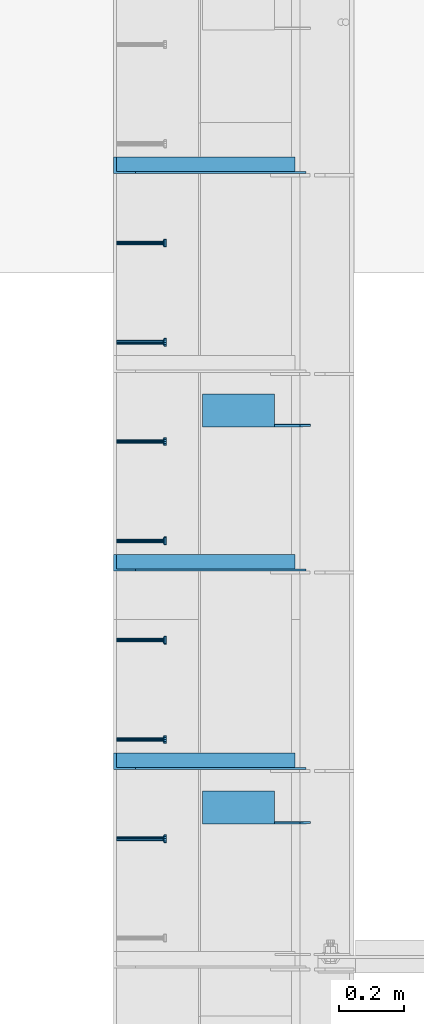
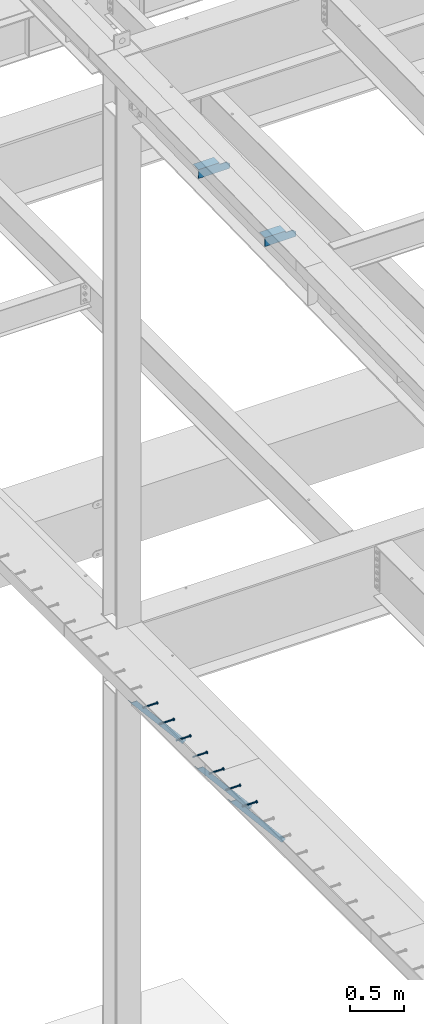
# One storey, part 1279 of 1763: 9 beams, 3 members, 9 elements without a shape of their own.
"""IFC2X3 building model written with IfcOpenShell, lengths in millimetres."""

from ifc_helpers import new_model, si_unit, frame, origin_with_axes, place, context, subcontext, project, spatial, faceted_brep, material, type_object, element, aggregate, save


model = new_model("IFC2X3")

# Units and contexts
model_context = context("Model", 3, precision=1e-05, world=origin_with_axes())
body_context = subcontext(model_context, "Body", "Model", "MODEL_VIEW")
ifc_project = project(units=[si_unit("LENGTHUNIT", "METRE", prefix="MILLI"), si_unit("AREAUNIT", "SQUARE_METRE"), si_unit("VOLUMEUNIT", "CUBIC_METRE"), si_unit("MASSUNIT", "GRAM", prefix="KILO"), si_unit("TIMEUNIT", "SECOND"), si_unit("PLANEANGLEUNIT", "RADIAN"), si_unit("SOLIDANGLEUNIT", "STERADIAN"), si_unit("THERMODYNAMICTEMPERATUREUNIT", "DEGREE_CELSIUS"), si_unit("LUMINOUSINTENSITYUNIT", "LUMEN")], contexts=[model_context])

# Site, building, storey
site_placement = place(None, origin_with_axes())
site = spatial("IfcSite", under=ifc_project, at=site_placement, CompositionType="ELEMENT")
building_placement = place(site_placement, origin_with_axes())
building = spatial("IfcBuilding", under=site, at=building_placement, Name="Undefined", CompositionType="ELEMENT")
storey_placement = place(building_placement, origin_with_axes())
storey = spatial("IfcBuildingStorey", under=building, at=storey_placement, Name="Undefined", CompositionType="ELEMENT", Elevation=0.0)

# Assembly, beam
assembly_1_placement = place(storey_placement, origin_with_axes())
assembly_1 = element("IfcElementAssembly", 1, at=assembly_1_placement, inside=storey, Name="HEADED STUD ANCHOR", AssemblyPlace="NOTDEFINED", PredefinedType="RIGID_FRAME")
ifc_material_1 = material(Name="STEEL/A108")
beam_type_1 = type_object("IfcBeamType", PredefinedType="NOTDEFINED")
beam_1_placement = place(assembly_1_placement, frame((-87975.5122736983, 41544.8750061035, 5268.91250001202), z_axis=(0.0, 0.0, -1.0), x_axis=(1.0, 0.0, 0.0)))
beam_1 = element("IfcBeam", 2, at=beam_1_placement, type_object=beam_type_1, material=ifc_material_1, Name="HEADED STUD ANCHOR", context=body_context, shape_type="Brep", body=[
    faceted_brep([(0.0, -3.1800000667572, 5.5), (0.0, -5.5, 3.1800000667572), (141.732000000002, -5.5, 3.1800000667572), (141.732000000002, -3.1800000667572, 5.5), (0.0, -6.34999999999491, 1.45519152283669e-11), (141.732000000002, -6.34999990463257, 0.0), (0.0, -5.5, -3.1800000667572), (141.732000000002, -5.5, -3.1800000667572), (0.0, -3.1800000667572, -5.5), (141.732000000002, -3.1800000667572, -5.5), (0.0, 0.0, -6.34999990463257), (141.732000000002, 0.0, -6.34999990463257), (0.0, 3.1800000667572, -5.5), (141.732000000002, 3.1800000667572, -5.5), (0.0, 5.5, -3.1800000667572), (141.732000000002, 5.5, -3.1800000667572), (0.0, 6.34999999999491, -2.91038304567337e-11), (141.732000000002, 6.34999990463257, 0.0), (0.0, 5.5, 3.1800000667572), (141.732000000002, 5.5, 3.1800000667572), (0.0, 3.1800000667572, 5.5), (141.732000000002, 3.1800000667572, 5.5), (0.0, 0.0, 6.34999990463257), (141.732000000002, 0.0, 6.34999990463257), (144.780000000001, -10.9899997711182, 6.34999990463257), (144.780000000001, -6.34000015258789, 10.9899997711182), (144.780000000001, -12.6999998092651, 0.0), (144.780000000001, -10.9899997711182, -6.34999990463257), (144.780000000001, -6.34000015258789, -10.9899997711182), (144.780000000001, 0.0, -12.6899995803833), (144.780000000001, 6.34000015258789, -10.9899997711182), (144.780000000001, 10.9899997711182, -6.34999990463257), (144.780000000001, 12.6999998092651, 0.0), (144.780000000001, 10.9899997711182, 6.34999990463257), (144.780000000001, 6.34000015258789, 10.9899997711182), (144.780000000001, 0.0, 12.6899995803833), (152.400000000001, -10.9899997711182, 6.34999990463257), (152.400000000001, -6.34000015258789, 10.9899997711182), (152.400000000001, -12.6999998092651, 0.0), (152.400000000001, -10.9899997711182, -6.34999990463257), (152.400000000001, -6.34000015258789, -10.9899997711182), (152.400000000001, 0.0, -12.6899995803833), (152.400000000001, 6.34000015258789, -10.9899997711182), (152.400000000001, 10.9899997711182, -6.34999990463257), (152.400000000001, 12.6999998092651, 0.0), (152.400000000001, 10.9899997711182, 6.34999990463257), (152.400000000001, 6.34000015258789, 10.9899997711182), (152.400000000001, 0.0, 12.6899995803833)], [[[0, 1, 2, 3]], [[1, 4, 5, 2]], [[4, 6, 7, 5]], [[6, 8, 9, 7]], [[8, 10, 11, 9]], [[10, 12, 13, 11]], [[12, 14, 15, 13]], [[14, 16, 17, 15]], [[16, 18, 19, 17]], [[18, 20, 21, 19]], [[20, 22, 23, 21]], [[22, 0, 3, 23]], [[22, 20, 18, 16, 14, 12, 10, 8, 6, 4, 1, 0]], [[3, 2, 24, 25]], [[2, 5, 26, 24]], [[5, 7, 27, 26]], [[7, 9, 28, 27]], [[9, 11, 29, 28]], [[11, 13, 30, 29]], [[13, 15, 31, 30]], [[15, 17, 32, 31]], [[17, 19, 33, 32]], [[19, 21, 34, 33]], [[21, 23, 35, 34]], [[23, 3, 25, 35]], [[25, 24, 36, 37]], [[24, 26, 38, 36]], [[26, 27, 39, 38]], [[27, 28, 40, 39]], [[28, 29, 41, 40]], [[29, 30, 42, 41]], [[30, 31, 43, 42]], [[31, 32, 44, 43]], [[32, 33, 45, 44]], [[33, 34, 46, 45]], [[34, 35, 47, 46]], [[35, 25, 37, 47]], [[38, 39, 40, 41, 42, 43, 44, 45, 46, 47, 37, 36]]]),
])
aggregate(assembly_1, [beam_1])

assembly_2_placement = place(storey_placement, origin_with_axes())
assembly_2 = element("IfcElementAssembly", 3, at=assembly_2_placement, inside=storey, Name="HEADED STUD ANCHOR", AssemblyPlace="NOTDEFINED", PredefinedType="RIGID_FRAME")
beam_2_placement = place(assembly_2_placement, frame((-87975.5122736983, 41849.6750061035, 5268.91250001202), z_axis=(0.0, 0.0, -1.0), x_axis=(1.0, 0.0, 0.0)))
beam_2 = element("IfcBeam", 4, at=beam_2_placement, type_object=beam_type_1, material=ifc_material_1, Name="HEADED STUD ANCHOR", context=body_context, shape_type="Brep", body=[
    faceted_brep([(0.0, -3.1800000667572, 5.5), (0.0, -5.5, 3.1800000667572), (141.732000000002, -5.5, 3.1800000667572), (141.732000000002, -3.1800000667572, 5.5), (0.0, -6.34999999999491, 1.45519152283669e-11), (141.732000000002, -6.34999990463257, 0.0), (0.0, -5.5, -3.1800000667572), (141.732000000002, -5.5, -3.1800000667572), (0.0, -3.1800000667572, -5.5), (141.732000000002, -3.1800000667572, -5.5), (0.0, 0.0, -6.34999990463257), (141.732000000002, 0.0, -6.34999990463257), (0.0, 3.1800000667572, -5.5), (141.732000000002, 3.1800000667572, -5.5), (0.0, 5.5, -3.1800000667572), (141.732000000002, 5.5, -3.1800000667572), (0.0, 6.34999999999491, -2.91038304567337e-11), (141.732000000002, 6.34999990463257, 0.0), (0.0, 5.5, 3.1800000667572), (141.732000000002, 5.5, 3.1800000667572), (0.0, 3.1800000667572, 5.5), (141.732000000002, 3.1800000667572, 5.5), (0.0, 0.0, 6.34999990463257), (141.732000000002, 0.0, 6.34999990463257), (144.780000000001, -10.9899997711182, 6.34999990463257), (144.780000000001, -6.34000015258789, 10.9899997711182), (144.780000000001, -12.6999998092651, 0.0), (144.780000000001, -10.9899997711182, -6.34999990463257), (144.780000000001, -6.34000015258789, -10.9899997711182), (144.780000000001, 0.0, -12.6899995803833), (144.780000000001, 6.34000015258789, -10.9899997711182), (144.780000000001, 10.9899997711182, -6.34999990463257), (144.780000000001, 12.6999998092651, 0.0), (144.780000000001, 10.9899997711182, 6.34999990463257), (144.780000000001, 6.34000015258789, 10.9899997711182), (144.780000000001, 0.0, 12.6899995803833), (152.400000000001, -10.9899997711182, 6.34999990463257), (152.400000000001, -6.34000015258789, 10.9899997711182), (152.400000000001, -12.6999998092651, 0.0), (152.400000000001, -10.9899997711182, -6.34999990463257), (152.400000000001, -6.34000015258789, -10.9899997711182), (152.400000000001, 0.0, -12.6899995803833), (152.400000000001, 6.34000015258789, -10.9899997711182), (152.400000000001, 10.9899997711182, -6.34999990463257), (152.400000000001, 12.6999998092651, 0.0), (152.400000000001, 10.9899997711182, 6.34999990463257), (152.400000000001, 6.34000015258789, 10.9899997711182), (152.400000000001, 0.0, 12.6899995803833)], [[[0, 1, 2, 3]], [[1, 4, 5, 2]], [[4, 6, 7, 5]], [[6, 8, 9, 7]], [[8, 10, 11, 9]], [[10, 12, 13, 11]], [[12, 14, 15, 13]], [[14, 16, 17, 15]], [[16, 18, 19, 17]], [[18, 20, 21, 19]], [[20, 22, 23, 21]], [[22, 0, 3, 23]], [[22, 20, 18, 16, 14, 12, 10, 8, 6, 4, 1, 0]], [[3, 2, 24, 25]], [[2, 5, 26, 24]], [[5, 7, 27, 26]], [[7, 9, 28, 27]], [[9, 11, 29, 28]], [[11, 13, 30, 29]], [[13, 15, 31, 30]], [[15, 17, 32, 31]], [[17, 19, 33, 32]], [[19, 21, 34, 33]], [[21, 23, 35, 34]], [[23, 3, 25, 35]], [[25, 24, 36, 37]], [[24, 26, 38, 36]], [[26, 27, 39, 38]], [[27, 28, 40, 39]], [[28, 29, 41, 40]], [[29, 30, 42, 41]], [[30, 31, 43, 42]], [[31, 32, 44, 43]], [[32, 33, 45, 44]], [[33, 34, 46, 45]], [[34, 35, 47, 46]], [[35, 25, 37, 47]], [[38, 39, 40, 41, 42, 43, 44, 45, 46, 47, 37, 36]]]),
])
aggregate(assembly_2, [beam_2])

assembly_3_placement = place(storey_placement, origin_with_axes())
assembly_3 = element("IfcElementAssembly", 5, at=assembly_3_placement, inside=storey, Name="HEADED STUD ANCHOR", AssemblyPlace="NOTDEFINED", PredefinedType="RIGID_FRAME")
beam_3_placement = place(assembly_3_placement, frame((-87975.5122736983, 42154.4750061035, 5268.91250001202), z_axis=(0.0, 0.0, -1.0), x_axis=(1.0, 0.0, 0.0)))
beam_3 = element("IfcBeam", 6, at=beam_3_placement, type_object=beam_type_1, material=ifc_material_1, Name="HEADED STUD ANCHOR", context=body_context, shape_type="Brep", body=[
    faceted_brep([(0.0, -3.1800000667572, 5.5), (0.0, -5.5, 3.1800000667572), (141.732000000002, -5.5, 3.1800000667572), (141.732000000002, -3.1800000667572, 5.5), (0.0, -6.34999999999491, 1.45519152283669e-11), (141.732000000002, -6.34999990463257, 0.0), (0.0, -5.5, -3.1800000667572), (141.732000000002, -5.5, -3.1800000667572), (0.0, -3.1800000667572, -5.5), (141.732000000002, -3.1800000667572, -5.5), (0.0, 0.0, -6.34999990463257), (141.732000000002, 0.0, -6.34999990463257), (0.0, 3.1800000667572, -5.5), (141.732000000002, 3.1800000667572, -5.5), (0.0, 5.5, -3.1800000667572), (141.732000000002, 5.5, -3.1800000667572), (0.0, 6.34999999999491, -2.91038304567337e-11), (141.732000000002, 6.34999990463257, 0.0), (0.0, 5.5, 3.1800000667572), (141.732000000002, 5.5, 3.1800000667572), (0.0, 3.1800000667572, 5.5), (141.732000000002, 3.1800000667572, 5.5), (0.0, 0.0, 6.34999990463257), (141.732000000002, 0.0, 6.34999990463257), (144.780000000001, -10.9899997711182, 6.34999990463257), (144.780000000001, -6.34000015258789, 10.9899997711182), (144.780000000001, -12.6999998092651, 0.0), (144.780000000001, -10.9899997711182, -6.34999990463257), (144.780000000001, -6.34000015258789, -10.9899997711182), (144.780000000001, 0.0, -12.6899995803833), (144.780000000001, 6.34000015258789, -10.9899997711182), (144.780000000001, 10.9899997711182, -6.34999990463257), (144.780000000001, 12.6999998092651, 0.0), (144.780000000001, 10.9899997711182, 6.34999990463257), (144.780000000001, 6.34000015258789, 10.9899997711182), (144.780000000001, 0.0, 12.6899995803833), (152.400000000001, -10.9899997711182, 6.34999990463257), (152.400000000001, -6.34000015258789, 10.9899997711182), (152.400000000001, -12.6999998092651, 0.0), (152.400000000001, -10.9899997711182, -6.34999990463257), (152.400000000001, -6.34000015258789, -10.9899997711182), (152.400000000001, 0.0, -12.6899995803833), (152.400000000001, 6.34000015258789, -10.9899997711182), (152.400000000001, 10.9899997711182, -6.34999990463257), (152.400000000001, 12.6999998092651, 0.0), (152.400000000001, 10.9899997711182, 6.34999990463257), (152.400000000001, 6.34000015258789, 10.9899997711182), (152.400000000001, 0.0, 12.6899995803833)], [[[0, 1, 2, 3]], [[1, 4, 5, 2]], [[4, 6, 7, 5]], [[6, 8, 9, 7]], [[8, 10, 11, 9]], [[10, 12, 13, 11]], [[12, 14, 15, 13]], [[14, 16, 17, 15]], [[16, 18, 19, 17]], [[18, 20, 21, 19]], [[20, 22, 23, 21]], [[22, 0, 3, 23]], [[22, 20, 18, 16, 14, 12, 10, 8, 6, 4, 1, 0]], [[3, 2, 24, 25]], [[2, 5, 26, 24]], [[5, 7, 27, 26]], [[7, 9, 28, 27]], [[9, 11, 29, 28]], [[11, 13, 30, 29]], [[13, 15, 31, 30]], [[15, 17, 32, 31]], [[17, 19, 33, 32]], [[19, 21, 34, 33]], [[21, 23, 35, 34]], [[23, 3, 25, 35]], [[25, 24, 36, 37]], [[24, 26, 38, 36]], [[26, 27, 39, 38]], [[27, 28, 40, 39]], [[28, 29, 41, 40]], [[29, 30, 42, 41]], [[30, 31, 43, 42]], [[31, 32, 44, 43]], [[32, 33, 45, 44]], [[33, 34, 46, 45]], [[34, 35, 47, 46]], [[35, 25, 37, 47]], [[38, 39, 40, 41, 42, 43, 44, 45, 46, 47, 37, 36]]]),
])
aggregate(assembly_3, [beam_3])

assembly_4_placement = place(storey_placement, origin_with_axes())
assembly_4 = element("IfcElementAssembly", 7, at=assembly_4_placement, inside=storey, Name="HEADED STUD ANCHOR", AssemblyPlace="NOTDEFINED", PredefinedType="RIGID_FRAME")
beam_4_placement = place(assembly_4_placement, frame((-87975.5122736983, 42459.2750061035, 5268.91250001202), z_axis=(0.0, 0.0, -1.0), x_axis=(1.0, 0.0, 0.0)))
beam_4 = element("IfcBeam", 8, at=beam_4_placement, type_object=beam_type_1, material=ifc_material_1, Name="HEADED STUD ANCHOR", context=body_context, shape_type="Brep", body=[
    faceted_brep([(0.0, -3.1800000667572, 5.5), (0.0, -5.5, 3.1800000667572), (141.732000000002, -5.5, 3.1800000667572), (141.732000000002, -3.1800000667572, 5.5), (0.0, -6.34999999999491, 1.45519152283669e-11), (141.732000000002, -6.34999990463257, 0.0), (0.0, -5.5, -3.1800000667572), (141.732000000002, -5.5, -3.1800000667572), (0.0, -3.1800000667572, -5.5), (141.732000000002, -3.1800000667572, -5.5), (0.0, 0.0, -6.34999990463257), (141.732000000002, 0.0, -6.34999990463257), (0.0, 3.1800000667572, -5.5), (141.732000000002, 3.1800000667572, -5.5), (0.0, 5.5, -3.1800000667572), (141.732000000002, 5.5, -3.1800000667572), (0.0, 6.34999999999491, -2.91038304567337e-11), (141.732000000002, 6.34999990463257, 0.0), (0.0, 5.5, 3.1800000667572), (141.732000000002, 5.5, 3.1800000667572), (0.0, 3.1800000667572, 5.5), (141.732000000002, 3.1800000667572, 5.5), (0.0, 0.0, 6.34999990463257), (141.732000000002, 0.0, 6.34999990463257), (144.780000000001, -10.9899997711182, 6.34999990463257), (144.780000000001, -6.34000015258789, 10.9899997711182), (144.780000000001, -12.6999998092651, 0.0), (144.780000000001, -10.9899997711182, -6.34999990463257), (144.780000000001, -6.34000015258789, -10.9899997711182), (144.780000000001, 0.0, -12.6899995803833), (144.780000000001, 6.34000015258789, -10.9899997711182), (144.780000000001, 10.9899997711182, -6.34999990463257), (144.780000000001, 12.6999998092651, 0.0), (144.780000000001, 10.9899997711182, 6.34999990463257), (144.780000000001, 6.34000015258789, 10.9899997711182), (144.780000000001, 0.0, 12.6899995803833), (152.400000000001, -10.9899997711182, 6.34999990463257), (152.400000000001, -6.34000015258789, 10.9899997711182), (152.400000000001, -12.6999998092651, 0.0), (152.400000000001, -10.9899997711182, -6.34999990463257), (152.400000000001, -6.34000015258789, -10.9899997711182), (152.400000000001, 0.0, -12.6899995803833), (152.400000000001, 6.34000015258789, -10.9899997711182), (152.400000000001, 10.9899997711182, -6.34999990463257), (152.400000000001, 12.6999998092651, 0.0), (152.400000000001, 10.9899997711182, 6.34999990463257), (152.400000000001, 6.34000015258789, 10.9899997711182), (152.400000000001, 0.0, 12.6899995803833)], [[[0, 1, 2, 3]], [[1, 4, 5, 2]], [[4, 6, 7, 5]], [[6, 8, 9, 7]], [[8, 10, 11, 9]], [[10, 12, 13, 11]], [[12, 14, 15, 13]], [[14, 16, 17, 15]], [[16, 18, 19, 17]], [[18, 20, 21, 19]], [[20, 22, 23, 21]], [[22, 0, 3, 23]], [[22, 20, 18, 16, 14, 12, 10, 8, 6, 4, 1, 0]], [[3, 2, 24, 25]], [[2, 5, 26, 24]], [[5, 7, 27, 26]], [[7, 9, 28, 27]], [[9, 11, 29, 28]], [[11, 13, 30, 29]], [[13, 15, 31, 30]], [[15, 17, 32, 31]], [[17, 19, 33, 32]], [[19, 21, 34, 33]], [[21, 23, 35, 34]], [[23, 3, 25, 35]], [[25, 24, 36, 37]], [[24, 26, 38, 36]], [[26, 27, 39, 38]], [[27, 28, 40, 39]], [[28, 29, 41, 40]], [[29, 30, 42, 41]], [[30, 31, 43, 42]], [[31, 32, 44, 43]], [[32, 33, 45, 44]], [[33, 34, 46, 45]], [[34, 35, 47, 46]], [[35, 25, 37, 47]], [[38, 39, 40, 41, 42, 43, 44, 45, 46, 47, 37, 36]]]),
])
aggregate(assembly_4, [beam_4])

assembly_5_placement = place(storey_placement, origin_with_axes())
assembly_5 = element("IfcElementAssembly", 9, at=assembly_5_placement, inside=storey, Name="HEADED STUD ANCHOR", AssemblyPlace="NOTDEFINED", PredefinedType="RIGID_FRAME")
beam_5_placement = place(assembly_5_placement, frame((-87975.5122736983, 42764.0750061035, 5268.91250001202), z_axis=(0.0, 0.0, -1.0), x_axis=(1.0, 0.0, 0.0)))
beam_5 = element("IfcBeam", 10, at=beam_5_placement, type_object=beam_type_1, material=ifc_material_1, Name="HEADED STUD ANCHOR", context=body_context, shape_type="Brep", body=[
    faceted_brep([(0.0, -3.1800000667572, 5.5), (0.0, -5.5, 3.1800000667572), (141.732000000002, -5.5, 3.1800000667572), (141.732000000002, -3.1800000667572, 5.5), (0.0, -6.34999999999491, 1.45519152283669e-11), (141.732000000002, -6.34999990463257, 0.0), (0.0, -5.5, -3.1800000667572), (141.732000000002, -5.5, -3.1800000667572), (0.0, -3.1800000667572, -5.5), (141.732000000002, -3.1800000667572, -5.5), (0.0, 0.0, -6.34999990463257), (141.732000000002, 0.0, -6.34999990463257), (0.0, 3.1800000667572, -5.5), (141.732000000002, 3.1800000667572, -5.5), (0.0, 5.5, -3.1800000667572), (141.732000000002, 5.5, -3.1800000667572), (0.0, 6.34999999999491, -2.91038304567337e-11), (141.732000000002, 6.34999990463257, 0.0), (0.0, 5.5, 3.1800000667572), (141.732000000002, 5.5, 3.1800000667572), (0.0, 3.1800000667572, 5.5), (141.732000000002, 3.1800000667572, 5.5), (0.0, 0.0, 6.34999990463257), (141.732000000002, 0.0, 6.34999990463257), (144.780000000001, -10.9899997711182, 6.34999990463257), (144.780000000001, -6.34000015258789, 10.9899997711182), (144.780000000001, -12.6999998092651, 0.0), (144.780000000001, -10.9899997711182, -6.34999990463257), (144.780000000001, -6.34000015258789, -10.9899997711182), (144.780000000001, 0.0, -12.6899995803833), (144.780000000001, 6.34000015258789, -10.9899997711182), (144.780000000001, 10.9899997711182, -6.34999990463257), (144.780000000001, 12.6999998092651, 0.0), (144.780000000001, 10.9899997711182, 6.34999990463257), (144.780000000001, 6.34000015258789, 10.9899997711182), (144.780000000001, 0.0, 12.6899995803833), (152.400000000001, -10.9899997711182, 6.34999990463257), (152.400000000001, -6.34000015258789, 10.9899997711182), (152.400000000001, -12.6999998092651, 0.0), (152.400000000001, -10.9899997711182, -6.34999990463257), (152.400000000001, -6.34000015258789, -10.9899997711182), (152.400000000001, 0.0, -12.6899995803833), (152.400000000001, 6.34000015258789, -10.9899997711182), (152.400000000001, 10.9899997711182, -6.34999990463257), (152.400000000001, 12.6999998092651, 0.0), (152.400000000001, 10.9899997711182, 6.34999990463257), (152.400000000001, 6.34000015258789, 10.9899997711182), (152.400000000001, 0.0, 12.6899995803833)], [[[0, 1, 2, 3]], [[1, 4, 5, 2]], [[4, 6, 7, 5]], [[6, 8, 9, 7]], [[8, 10, 11, 9]], [[10, 12, 13, 11]], [[12, 14, 15, 13]], [[14, 16, 17, 15]], [[16, 18, 19, 17]], [[18, 20, 21, 19]], [[20, 22, 23, 21]], [[22, 0, 3, 23]], [[22, 20, 18, 16, 14, 12, 10, 8, 6, 4, 1, 0]], [[3, 2, 24, 25]], [[2, 5, 26, 24]], [[5, 7, 27, 26]], [[7, 9, 28, 27]], [[9, 11, 29, 28]], [[11, 13, 30, 29]], [[13, 15, 31, 30]], [[15, 17, 32, 31]], [[17, 19, 33, 32]], [[19, 21, 34, 33]], [[21, 23, 35, 34]], [[23, 3, 25, 35]], [[25, 24, 36, 37]], [[24, 26, 38, 36]], [[26, 27, 39, 38]], [[27, 28, 40, 39]], [[28, 29, 41, 40]], [[29, 30, 42, 41]], [[30, 31, 43, 42]], [[31, 32, 44, 43]], [[32, 33, 45, 44]], [[33, 34, 46, 45]], [[34, 35, 47, 46]], [[35, 25, 37, 47]], [[38, 39, 40, 41, 42, 43, 44, 45, 46, 47, 37, 36]]]),
])
aggregate(assembly_5, [beam_5])

assembly_6_placement = place(storey_placement, origin_with_axes())
assembly_6 = element("IfcElementAssembly", 11, at=assembly_6_placement, inside=storey, Name="HEADED STUD ANCHOR", AssemblyPlace="NOTDEFINED", PredefinedType="RIGID_FRAME")
beam_6_placement = place(assembly_6_placement, frame((-87975.5122736983, 43068.8750061035, 5268.91250001202), z_axis=(0.0, 0.0, -1.0), x_axis=(1.0, 0.0, 0.0)))
beam_6 = element("IfcBeam", 12, at=beam_6_placement, type_object=beam_type_1, material=ifc_material_1, Name="HEADED STUD ANCHOR", context=body_context, shape_type="Brep", body=[
    faceted_brep([(0.0, -3.1800000667572, 5.5), (0.0, -5.5, 3.1800000667572), (141.732000000002, -5.5, 3.1800000667572), (141.732000000002, -3.1800000667572, 5.5), (0.0, -6.34999999999491, 1.45519152283669e-11), (141.732000000002, -6.34999990463257, 0.0), (0.0, -5.5, -3.1800000667572), (141.732000000002, -5.5, -3.1800000667572), (0.0, -3.1800000667572, -5.5), (141.732000000002, -3.1800000667572, -5.5), (0.0, 0.0, -6.34999990463257), (141.732000000002, 0.0, -6.34999990463257), (0.0, 3.1800000667572, -5.5), (141.732000000002, 3.1800000667572, -5.5), (0.0, 5.5, -3.1800000667572), (141.732000000002, 5.5, -3.1800000667572), (0.0, 6.34999999999491, -2.91038304567337e-11), (141.732000000002, 6.34999990463257, 0.0), (0.0, 5.5, 3.1800000667572), (141.732000000002, 5.5, 3.1800000667572), (0.0, 3.1800000667572, 5.5), (141.732000000002, 3.1800000667572, 5.5), (0.0, 0.0, 6.34999990463257), (141.732000000002, 0.0, 6.34999990463257), (144.780000000001, -10.9899997711182, 6.34999990463257), (144.780000000001, -6.34000015258789, 10.9899997711182), (144.780000000001, -12.6999998092651, 0.0), (144.780000000001, -10.9899997711182, -6.34999990463257), (144.780000000001, -6.34000015258789, -10.9899997711182), (144.780000000001, 0.0, -12.6899995803833), (144.780000000001, 6.34000015258789, -10.9899997711182), (144.780000000001, 10.9899997711182, -6.34999990463257), (144.780000000001, 12.6999998092651, 0.0), (144.780000000001, 10.9899997711182, 6.34999990463257), (144.780000000001, 6.34000015258789, 10.9899997711182), (144.780000000001, 0.0, 12.6899995803833), (152.400000000001, -10.9899997711182, 6.34999990463257), (152.400000000001, -6.34000015258789, 10.9899997711182), (152.400000000001, -12.6999998092651, 0.0), (152.400000000001, -10.9899997711182, -6.34999990463257), (152.400000000001, -6.34000015258789, -10.9899997711182), (152.400000000001, 0.0, -12.6899995803833), (152.400000000001, 6.34000015258789, -10.9899997711182), (152.400000000001, 10.9899997711182, -6.34999990463257), (152.400000000001, 12.6999998092651, 0.0), (152.400000000001, 10.9899997711182, 6.34999990463257), (152.400000000001, 6.34000015258789, 10.9899997711182), (152.400000000001, 0.0, 12.6899995803833)], [[[0, 1, 2, 3]], [[1, 4, 5, 2]], [[4, 6, 7, 5]], [[6, 8, 9, 7]], [[8, 10, 11, 9]], [[10, 12, 13, 11]], [[12, 14, 15, 13]], [[14, 16, 17, 15]], [[16, 18, 19, 17]], [[18, 20, 21, 19]], [[20, 22, 23, 21]], [[22, 0, 3, 23]], [[22, 20, 18, 16, 14, 12, 10, 8, 6, 4, 1, 0]], [[3, 2, 24, 25]], [[2, 5, 26, 24]], [[5, 7, 27, 26]], [[7, 9, 28, 27]], [[9, 11, 29, 28]], [[11, 13, 30, 29]], [[13, 15, 31, 30]], [[15, 17, 32, 31]], [[17, 19, 33, 32]], [[19, 21, 34, 33]], [[21, 23, 35, 34]], [[23, 3, 25, 35]], [[25, 24, 36, 37]], [[24, 26, 38, 36]], [[26, 27, 39, 38]], [[27, 28, 40, 39]], [[28, 29, 41, 40]], [[29, 30, 42, 41]], [[30, 31, 43, 42]], [[31, 32, 44, 43]], [[32, 33, 45, 44]], [[33, 34, 46, 45]], [[34, 35, 47, 46]], [[35, 25, 37, 47]], [[38, 39, 40, 41, 42, 43, 44, 45, 46, 47, 37, 36]]]),
])
aggregate(assembly_6, [beam_6])

assembly_7_placement = place(storey_placement, origin_with_axes())
assembly_7 = element("IfcElementAssembly", 13, at=assembly_7_placement, inside=storey, Name="HEADED STUD ANCHOR", AssemblyPlace="NOTDEFINED", PredefinedType="RIGID_FRAME")
beam_7_placement = place(assembly_7_placement, frame((-87975.5122736983, 43373.6750061035, 5268.91250001202), z_axis=(0.0, 0.0, -1.0), x_axis=(1.0, 0.0, 0.0)))
beam_7 = element("IfcBeam", 14, at=beam_7_placement, type_object=beam_type_1, material=ifc_material_1, Name="HEADED STUD ANCHOR", context=body_context, shape_type="Brep", body=[
    faceted_brep([(0.0, -3.1800000667572, 5.5), (0.0, -5.5, 3.1800000667572), (141.732000000002, -5.5, 3.1800000667572), (141.732000000002, -3.1800000667572, 5.5), (0.0, -6.34999999999491, 1.45519152283669e-11), (141.732000000002, -6.34999990463257, 0.0), (0.0, -5.5, -3.1800000667572), (141.732000000002, -5.5, -3.1800000667572), (0.0, -3.1800000667572, -5.5), (141.732000000002, -3.1800000667572, -5.5), (0.0, 0.0, -6.34999990463257), (141.732000000002, 0.0, -6.34999990463257), (0.0, 3.1800000667572, -5.5), (141.732000000002, 3.1800000667572, -5.5), (0.0, 5.5, -3.1800000667572), (141.732000000002, 5.5, -3.1800000667572), (0.0, 6.34999999999491, -2.91038304567337e-11), (141.732000000002, 6.34999990463257, 0.0), (0.0, 5.5, 3.1800000667572), (141.732000000002, 5.5, 3.1800000667572), (0.0, 3.1800000667572, 5.5), (141.732000000002, 3.1800000667572, 5.5), (0.0, 0.0, 6.34999990463257), (141.732000000002, 0.0, 6.34999990463257), (144.780000000001, -10.9899997711182, 6.34999990463257), (144.780000000001, -6.34000015258789, 10.9899997711182), (144.780000000001, -12.6999998092651, 0.0), (144.780000000001, -10.9899997711182, -6.34999990463257), (144.780000000001, -6.34000015258789, -10.9899997711182), (144.780000000001, 0.0, -12.6899995803833), (144.780000000001, 6.34000015258789, -10.9899997711182), (144.780000000001, 10.9899997711182, -6.34999990463257), (144.780000000001, 12.6999998092651, 0.0), (144.780000000001, 10.9899997711182, 6.34999990463257), (144.780000000001, 6.34000015258789, 10.9899997711182), (144.780000000001, 0.0, 12.6899995803833), (152.400000000001, -10.9899997711182, 6.34999990463257), (152.400000000001, -6.34000015258789, 10.9899997711182), (152.400000000001, -12.6999998092651, 0.0), (152.400000000001, -10.9899997711182, -6.34999990463257), (152.400000000001, -6.34000015258789, -10.9899997711182), (152.400000000001, 0.0, -12.6899995803833), (152.400000000001, 6.34000015258789, -10.9899997711182), (152.400000000001, 10.9899997711182, -6.34999990463257), (152.400000000001, 12.6999998092651, 0.0), (152.400000000001, 10.9899997711182, 6.34999990463257), (152.400000000001, 6.34000015258789, 10.9899997711182), (152.400000000001, 0.0, 12.6899995803833)], [[[0, 1, 2, 3]], [[1, 4, 5, 2]], [[4, 6, 7, 5]], [[6, 8, 9, 7]], [[8, 10, 11, 9]], [[10, 12, 13, 11]], [[12, 14, 15, 13]], [[14, 16, 17, 15]], [[16, 18, 19, 17]], [[18, 20, 21, 19]], [[20, 22, 23, 21]], [[22, 0, 3, 23]], [[22, 20, 18, 16, 14, 12, 10, 8, 6, 4, 1, 0]], [[3, 2, 24, 25]], [[2, 5, 26, 24]], [[5, 7, 27, 26]], [[7, 9, 28, 27]], [[9, 11, 29, 28]], [[11, 13, 30, 29]], [[13, 15, 31, 30]], [[15, 17, 32, 31]], [[17, 19, 33, 32]], [[19, 21, 34, 33]], [[21, 23, 35, 34]], [[23, 3, 25, 35]], [[25, 24, 36, 37]], [[24, 26, 38, 36]], [[26, 27, 39, 38]], [[27, 28, 40, 39]], [[28, 29, 41, 40]], [[29, 30, 42, 41]], [[30, 31, 43, 42]], [[31, 32, 44, 43]], [[32, 33, 45, 44]], [[33, 34, 46, 45]], [[34, 35, 47, 46]], [[35, 25, 37, 47]], [[38, 39, 40, 41, 42, 43, 44, 45, 46, 47, 37, 36]]]),
])
aggregate(assembly_7, [beam_7])

# Assembly, members
assembly_8_placement = place(storey_placement, origin_with_axes())
assembly_8 = element("IfcElementAssembly", 15, at=assembly_8_placement, inside=storey, Name="BEAM", AssemblyPlace="NOTDEFINED", PredefinedType="RIGID_FRAME")
ifc_material_2 = material(Name="STEEL/A36")
member_type = type_object("IfcMemberType", Name="L2X2X1/4", PredefinedType="NOTDEFINED")
member_1_placement = place(assembly_8_placement, frame((-87414.1929584935, 43611.8, 4557.35349338836), z_axis=(0.764183480307171, 0.0, 0.644998921259268), x_axis=(-0.644998921259266, 0.0, 0.764183480307173)))
member_1 = element("IfcMember", 16, at=member_1_placement, type_object=member_type, material=ifc_material_2, Name="ANGLE", ObjectType="L2X2X1/4", context=body_context, shape_type="Brep", body=[
    faceted_brep([(-1.45519152283669e-11, 25.4000000000015, -25.3999999999869), (1.45519152283669e-11, 25.4000000000015, 25.3999999999796), (812.060911532491, 25.4000000000015, 25.400000001966), (854.937976763787, 25.4000000000015, -25.3999999979424), (1.45519152283669e-11, 19.0499999999993, 25.3999999999796), (812.060911532491, 19.0500000000029, 25.400000001966), (-7.27595761418343e-12, 19.0499999999993, -19.0499999999956), (849.578343609872, 19.0500000000029, -19.0499999979511), (-7.27595761418343e-12, -25.4000000000015, -19.0499999999956), (849.578343609872, -25.4000000000015, -19.0499999979511), (-1.45519152283669e-11, -25.4000000000015, -25.3999999999869), (854.937976763787, -25.4000000000015, -25.3999999979424)], [[[0, 1, 2, 3]], [[1, 4, 5, 2]], [[4, 6, 7, 5]], [[6, 8, 9, 7]], [[8, 10, 11, 9]], [[10, 0, 3, 11]], [[5, 7, 9, 11, 3, 2]], [[10, 8, 6, 4, 1, 0]]]),
])
member_2_placement = place(assembly_8_placement, frame((-87414.1929584935, 42392.6, 4557.35349338836), z_axis=(0.764183480307171, 0.0, 0.644998921259268), x_axis=(-0.644998921259266, 0.0, 0.764183480307173)))
member_2 = element("IfcMember", 17, at=member_2_placement, type_object=member_type, material=ifc_material_2, Name="ANGLE", ObjectType="L2X2X1/4", context=body_context, shape_type="Brep", body=[
    faceted_brep([(-1.45519152283669e-11, 25.4000000000015, -25.3999999999869), (1.45519152283669e-11, 25.4000000000015, 25.3999999999796), (812.060911532491, 25.4000000000015, 25.400000001966), (854.937976763787, 25.4000000000015, -25.3999999979424), (1.45519152283669e-11, 19.0499999999993, 25.3999999999796), (812.060911532491, 19.0500000000029, 25.400000001966), (-7.27595761418343e-12, 19.0499999999993, -19.0499999999956), (849.578343609872, 19.0500000000029, -19.0499999979511), (-7.27595761418343e-12, -25.4000000000015, -19.0499999999956), (849.578343609872, -25.4000000000015, -19.0499999979511), (-1.45519152283669e-11, -25.4000000000015, -25.3999999999869), (854.937976763787, -25.4000000000015, -25.3999999979424)], [[[0, 1, 2, 3]], [[1, 4, 5, 2]], [[4, 6, 7, 5]], [[6, 8, 9, 7]], [[8, 10, 11, 9]], [[10, 0, 3, 11]], [[5, 7, 9, 11, 3, 2]], [[10, 8, 6, 4, 1, 0]]]),
])
member_3_placement = place(assembly_8_placement, frame((-87414.1929584935, 41783.0, 4557.35349338836), z_axis=(0.764183480307171, 0.0, 0.644998921259268), x_axis=(-0.644998921259266, 0.0, 0.764183480307173)))
member_3 = element("IfcMember", 18, at=member_3_placement, type_object=member_type, material=ifc_material_2, Name="ANGLE", ObjectType="L2X2X1/4", context=body_context, shape_type="Brep", body=[
    faceted_brep([(-1.45519152283669e-11, 25.4000000000015, -25.3999999999869), (1.45519152283669e-11, 25.4000000000015, 25.3999999999796), (812.060911532491, 25.4000000000015, 25.400000001966), (854.937976763787, 25.4000000000015, -25.3999999979424), (1.45519152283669e-11, 19.0499999999993, 25.3999999999796), (812.060911532491, 19.0500000000029, 25.400000001966), (-7.27595761418343e-12, 19.0499999999993, -19.0499999999956), (849.578343609872, 19.0500000000029, -19.0499999979511), (-7.27595761418343e-12, -25.4000000000015, -19.0499999999956), (849.578343609872, -25.4000000000015, -19.0499999979511), (-1.45519152283669e-11, -25.4000000000015, -25.3999999999869), (854.937976763787, -25.4000000000015, -25.3999999979424)], [[[0, 1, 2, 3]], [[1, 4, 5, 2]], [[4, 6, 7, 5]], [[6, 8, 9, 7]], [[8, 10, 11, 9]], [[10, 0, 3, 11]], [[5, 7, 9, 11, 3, 2]], [[10, 8, 6, 4, 1, 0]]]),
])
aggregate(assembly_8, [member_1, member_2, member_3])

# Assembly, beams
assembly_9_placement = place(storey_placement, origin_with_axes())
assembly_9 = element("IfcElementAssembly", 19, at=assembly_9_placement, inside=storey, Name="BEAM", AssemblyPlace="NOTDEFINED", PredefinedType="RIGID_FRAME")
beam_type_2 = type_object("IfcBeamType", Name="L4X4X1/4", PredefinedType="NOTDEFINED")
beam_8_placement = place(assembly_9_placement, frame((-87711.9872706466, 42860.828542246, 11505.1035072356), z_axis=(0.0, 0.0206852279954837, -0.999786037781472), x_axis=(1.0, 0.0, 0.0)))
beam_8 = element("IfcBeam", 20, at=beam_8_placement, type_object=beam_type_2, material=ifc_material_2, Name="BRACE", ObjectType="L4X4X1/4", context=body_context, shape_type="Brep", body=[
    faceted_brep([(220.662761923406, 44.4500000001208, -44.4499999999807), (220.662761962012, -50.800000000163, -44.4499999999553), (220.66276795695, -50.800000000163, -50.7999999999502), (220.662767915564, 50.8000000001339, -50.7999999999774), (220.662751535681, 50.8000000001339, -33.3786578752915), (220.662751538272, 44.4500000001208, -33.3786578752897), (299.243730570859, 44.4500000001135, -33.3375021376705), (299.243730570859, 50.8000000001339, -33.3375021376723), (2.11002770811319e-10, -50.8000000000357, -50.799999999952), (1.96450855582952e-10, -50.8000000000338, -44.4499999999534), (-2.18278728425503e-11, 44.4500000000007, -44.450000000048), (-1.81898940354586e-10, 44.4500000000371, 50.7999999999374), (-1.96450855582952e-10, 50.8000000000393, 50.7999999999374), (-3.63797880709171e-11, 50.8000000000011, -50.8000000000538), (330.993731689443, 44.4500000000007, 50.7999999999993), (330.993731689443, 50.7999999999993, 50.7999999999993), (330.993730570859, 44.4500000001281, -1.58750213774329), (330.993746948254, 50.8000000001412, -1.5875021377451)], [[[0, 1, 2, 3, 4, 5]], [[6, 5, 4, 7]], [[8, 9, 10, 11, 12, 13]], [[12, 11, 14, 15]], [[15, 14, 16, 17]], [[17, 16, 6, 7]], [[3, 13, 12, 15, 17, 7, 4]], [[8, 13, 3, 2]], [[9, 8, 2, 1]], [[10, 9, 1, 0]], [[16, 14, 11, 10, 0, 5, 6]]]),
])
beam_9_placement = place(assembly_9_placement, frame((-87711.9872706466, 41641.8894049831, 11479.8840772636), z_axis=(0.0, 0.0206852279954837, -0.999786037781472), x_axis=(1.0, 0.0, 0.0)))
beam_9 = element("IfcBeam", 21, at=beam_9_placement, type_object=beam_type_2, material=ifc_material_2, Name="BRACE", ObjectType="L4X4X1/4", context=body_context, shape_type="Brep", body=[
    faceted_brep([(220.662761923406, 44.4500000001208, -44.4499999999807), (220.662761962012, -50.800000000163, -44.4499999999553), (220.66276795695, -50.800000000163, -50.7999999999502), (220.662767915564, 50.8000000001339, -50.7999999999774), (220.662751535681, 50.8000000001339, -33.3786578752915), (220.662751538272, 44.4500000001208, -33.3786578752897), (299.243730570859, 44.4500000001135, -33.3375021376705), (299.243730570859, 50.8000000001339, -33.3375021376723), (2.11002770811319e-10, -50.8000000000357, -50.799999999952), (1.96450855582952e-10, -50.8000000000338, -44.4499999999534), (-2.18278728425503e-11, 44.4500000000007, -44.450000000048), (-1.81898940354586e-10, 44.4500000000371, 50.7999999999374), (-1.96450855582952e-10, 50.8000000000393, 50.7999999999374), (-3.63797880709171e-11, 50.8000000000011, -50.8000000000538), (330.993731689443, 44.4500000000007, 50.7999999999993), (330.993731689443, 50.7999999999993, 50.7999999999993), (330.993730570859, 44.4500000001281, -1.58750213774329), (330.993746948254, 50.8000000001412, -1.5875021377451)], [[[0, 1, 2, 3, 4, 5]], [[6, 5, 4, 7]], [[8, 9, 10, 11, 12, 13]], [[12, 11, 14, 15]], [[15, 14, 16, 17]], [[17, 16, 6, 7]], [[3, 13, 12, 15, 17, 7, 4]], [[8, 13, 3, 2]], [[9, 8, 2, 1]], [[10, 9, 1, 0]], [[16, 14, 11, 10, 0, 5, 6]]]),
])
aggregate(assembly_9, [beam_8, beam_9])

save(model, "model.ifc")
